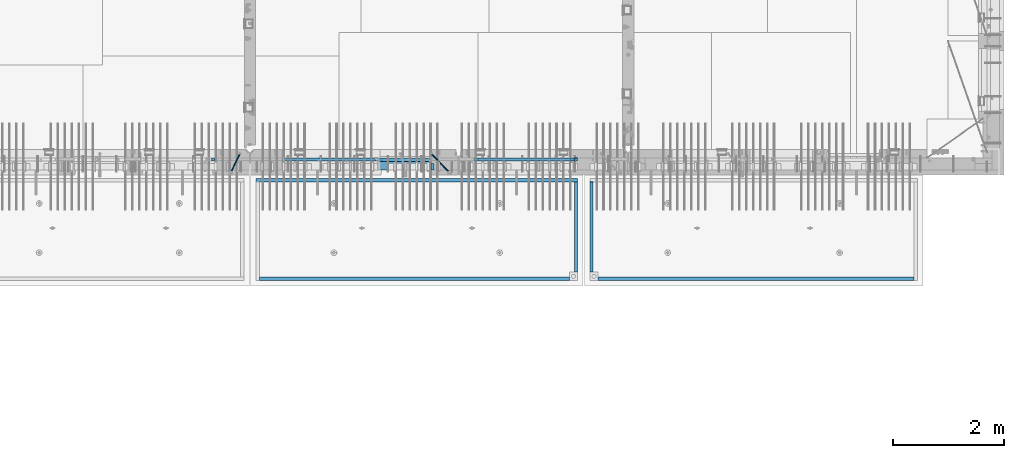
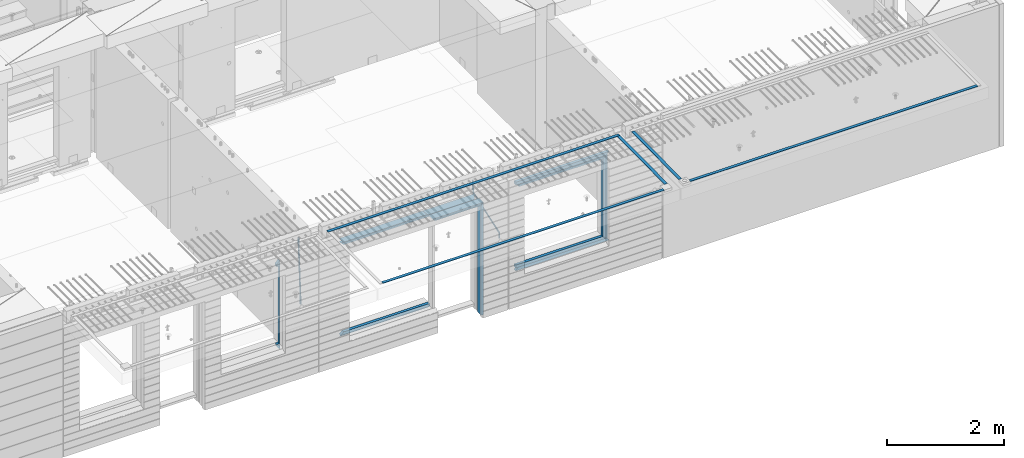
# One storey, part 96 of 352: 22 beams, 5 elements without a shape of their own.
"""IFC2X3 building model written with IfcOpenShell, lengths in millimetres."""

from ifc_helpers import new_model, si_unit, frame, origin_with_axes, place, context, subcontext, project, spatial, faceted_brep, material, type_object, element, aggregate, save


model = new_model("IFC2X3")

# Units and contexts
model_context = context("Model", 3, precision=1e-05, world=origin_with_axes())
body_context = subcontext(model_context, "Body", "Model", "MODEL_VIEW")
ifc_project = project(units=[si_unit("LENGTHUNIT", "METRE", prefix="MILLI"), si_unit("AREAUNIT", "SQUARE_METRE"), si_unit("VOLUMEUNIT", "CUBIC_METRE"), si_unit("MASSUNIT", "GRAM", prefix="KILO"), si_unit("TIMEUNIT", "SECOND"), si_unit("PLANEANGLEUNIT", "RADIAN"), si_unit("SOLIDANGLEUNIT", "STERADIAN"), si_unit("THERMODYNAMICTEMPERATUREUNIT", "DEGREE_CELSIUS"), si_unit("LUMINOUSINTENSITYUNIT", "LUMEN")], contexts=[model_context])

# Site, building, storey
site_placement = place(None, origin_with_axes())
site = spatial("IfcSite", under=ifc_project, at=site_placement, CompositionType="ELEMENT")
building_placement = place(site_placement, origin_with_axes())
building = spatial("IfcBuilding", under=site, at=building_placement, CompositionType="ELEMENT")
storey_placement = place(building_placement, origin_with_axes())
storey = spatial("IfcBuildingStorey", under=building, at=storey_placement, Name="6", CompositionType="ELEMENT", Elevation=0.0)

# Assembly, beams
assembly_1_placement = place(storey_placement, origin_with_axes())
assembly_1 = element("IfcElementAssembly", 1, at=assembly_1_placement, inside=storey, AssemblyPlace="NOTDEFINED", PredefinedType="REINFORCEMENT_UNIT")
ifc_material_1 = material(Name="CONCRETE/C35/45")
beam_type_1 = type_object("IfcBeamType", PredefinedType="NOTDEFINED")
beam_1_placement = place(assembly_1_placement, frame((24034.9998642727, 7815.0, 99140.0), z_axis=(0.0, 0.0, -1.0), x_axis=(1.0, 0.0, 0.0)))
beam_1 = element("IfcBeam", 2, at=beam_1_placement, type_object=beam_type_1, material=ifc_material_1, Name="SK", context=body_context, shape_type="Brep", body=[
    faceted_brep([(70.0000000000164, -35.0, 35.0), (70.0000000000164, 35.0, 35.0), (0.0, -35.0, -35.0), (1039.99961853026, -35.0, -35.0), (980.889062997325, -35.0, 35.0), (980.889062997325, 35.0, 35.0)], [[[0, 1, 2]], [[0, 2, 3, 4]], [[1, 0, 4, 5]], [[2, 1, 5, 3]], [[4, 3, 5]]]),
])
ifc_material_2 = material(Name="TIMBER")
beam_type_2 = type_object("IfcBeamType", Name="50X150", PredefinedType="NOTDEFINED")
beam_2_placement = place(assembly_1_placement, frame((24104.9998642727, 7705.0, 99080.0), z_axis=(0.0, 0.0, -1.0), x_axis=(1.0, 0.0, 0.0)))
beam_2 = element("IfcBeam", 3, at=beam_2_placement, type_object=beam_type_2, material=ifc_material_2, ObjectType="50X150", context=body_context, shape_type="Brep", body=[
    faceted_brep([(50.0000000000036, -75.0, 25.0), (50.0000000000036, 75.0, 25.0), (0.0, 75.0, -25.0), (0.0, -75.0, -25.0), (1009.99961853027, -75.0, -25.0), (959.999618530259, -75.0, 25.0), (959.999618530259, 75.0, 25.0), (1009.99961853027, 75.0, -25.0)], [[[0, 1, 2, 3]], [[0, 3, 4, 5]], [[1, 0, 5, 6]], [[2, 1, 6, 7]], [[3, 2, 7, 4]], [[6, 5, 4, 7]]]),
])

# Assembly, beam
assembly_2_placement = place(storey_placement, origin_with_axes())
assembly_2 = element("IfcElementAssembly", 4, at=assembly_2_placement, inside=storey, AssemblyPlace="NOTDEFINED", PredefinedType="REINFORCEMENT_UNIT")
ifc_material_3 = material()
beam_type_3 = type_object("IfcBeamType", Name="D20", PredefinedType="NOTDEFINED")
beam_3_placement = place(assembly_2_placement, frame((21625.0073331492, 7924.99999997881, 99407.5), z_axis=(-0.000415599999849952, -0.999999913638316, 0.0), x_axis=(-6.05680000062309e-05, -4.00000390151988e-09, -0.999999998165759)))
beam_3 = element("IfcBeam", 5, at=beam_3_placement, type_object=beam_type_3, material=ifc_material_3, Name="JM20", ObjectType="D20", context=body_context, shape_type="Brep", body=[
    faceted_brep([(-0.00060564729210455, -9.99999998165731, 0.0), (-0.000428079845733009, -7.07106779890455, -7.07106781186667), (119.575515501536, -7.07830994756296, -7.07106481604933), (119.575337932896, -10.0072421307195, -3.43332612828817e-06), (0.0, 0.0, -10.0), (119.575943836026, -0.00724214867295814, -9.99999700418266), (0.00042843479604926, 7.07106779888636, -7.07106781186303), (119.57637202373, 7.06382565022977, -7.07106481604933), (0.00060564729210455, 9.99999998166459, 3.63797880709171e-12), (119.576549238118, 9.99275783300072, 2.99581552098971e-06), (0.000428079845733009, 7.07106779890819, 7.07106781186667), (119.576371669405, 7.06382565024978, 7.07107080768037), (0.0, 0.0, 10.0), (119.57594333493, -0.00724214864203532, 10.0000029958155), (-0.000428434810601175, -7.07106779888272, 7.07106781186667), (119.575515147211, -7.07830994754295, 7.07107080768037), (123.006973508192, -7.07825951346604, -6.96785036235087), (122.582196132164, -10.0072047447829, 0.090452766209637), (123.182421564867, -0.00718632049392909, -9.89150999405319), (123.005765870272, 7.06387605862983, -6.9678969281922), (122.5804889344, 9.99279518261392, 0.090375952400791), (122.155712218591, 7.06384995171538, 7.14866812117907), (121.980264161975, -0.00722324126036256, 10.0723277528814), (122.156919856599, -7.07828562038412, 7.14871468701676), (235.904703171851, -7.06860422895625, -0.169508357435916), (235.479926262604, -9.99754169577864, 6.88878701985595), (236.080151695453, 0.002465748351824, -3.09317573838871), (235.903496467319, 7.07353134315781, -0.16957042179456), (235.478219724217, 10.0024582304504, 6.88869924890878), (235.053442814489, 7.07352076285679, 13.9469946275131), (234.877994290917, 0.00245078554871725, 16.8706620084649), (235.05464951905, -7.06861480925727, 13.9470566918726), (247.69730842374, 6.49890140729985, 1.5904257279044), (247.708271375333, -0.564091162203113, -1.35790592567901), (246.351191555892, -7.5775885142175, 1.3894260566567), (244.421027918448, -10.4331790195793, 8.22307186000126), (243.04844414418, -7.45809648886643, 15.1399744532118), (243.037481192529, -0.395103919359826, 18.0883061067871), (244.394561011999, 6.61839343264, 15.3409741244495), (246.324724649443, 9.47398393802723, 8.50732832109588), (256.620302657771, 7.90789673379186, 11.9850227549905), (258.892076862918, 4.79603600307382, 5.371853429986), (253.26121545503, 5.26966351612282, 18.3359992487194), (250.782522980895, -1.57322241172369, 20.7044670154446), (250.636209669712, -8.61229127897968, 17.7030097594688), (252.907983874131, -11.724152010418, 11.0898404357176), (256.267071077629, -9.08591879203959, 4.7388639407518), (258.745763551793, -2.24303286420036, 2.37039617402661), (1008.47908473376, -166.485147783689, 337.205828025195), (1005.11999753102, -169.123381001344, 343.556804518913), (1010.95777720789, -159.642261855857, 334.837360258474), (1011.10409051905, -152.60319298859, 337.838817514449), (1008.83231631388, -149.491332257865, 344.451986839456), (1005.47322911114, -152.129565475519, 350.802963333173), (1002.99453663701, -158.972451403351, 353.171431099895), (1002.84822332587, -166.011520270618, 350.169973843918), (1010.17087503639, -166.839152352099, 337.953575170377), (1008.40147312843, -169.810024819315, 345.007169854448), (1011.47638800017, -159.75078038171, 335.066578819891), (1011.55326023143, -152.697181073247, 338.037344110582), (1010.35646101969, -149.810257238067, 345.125637025791), (1008.58705911171, -152.781129705283, 352.179231709861), (1007.28154614793, -159.869501675676, 355.066228060347), (1007.20467391667, -166.923100984135, 352.095462769656), (1012.05411677422, -166.839038287919, 337.953575122971), (1012.05429688386, -169.809803575103, 345.007169762499), (1012.05368737834, -159.750745415844, 335.066578805359), (1012.05326023052, -152.697150789249, 338.037344097996), (1012.05308554815, -149.81015447692, 345.125636983083), (1012.05326565779, -152.780919764096, 352.179231622609), (1012.05369505366, -159.869212636178, 355.066227940223), (1012.05412220149, -166.92280726277, 352.095462647586), (1117.510115663, -166.832651029355, 337.953572468433), (1117.51029577265, -169.803416316539, 345.00716710796), (1117.50968626713, -159.744358157277, 335.06657615082), (1117.50925911931, -152.690763530685, 338.037341443456), (1117.50908443694, -149.803767218353, 345.125634328543), (1117.50926454658, -152.774532505533, 352.17922896807), (1117.50969394245, -159.862825377615, 355.066225285684), (1117.51012109026, -166.916420004207, 352.095459993046)], [[[0, 1, 2, 3]], [[1, 4, 5, 2]], [[4, 6, 7, 5]], [[6, 8, 9, 7]], [[8, 10, 11, 9]], [[10, 12, 13, 11]], [[12, 14, 15, 13]], [[14, 0, 3, 15]], [[14, 12, 10, 8, 6, 4, 1, 0]], [[3, 2, 16, 17]], [[2, 5, 18, 16]], [[5, 7, 19, 18]], [[7, 9, 20, 19]], [[9, 11, 21, 20]], [[11, 13, 22, 21]], [[13, 15, 23, 22]], [[15, 3, 17, 23]], [[17, 16, 24, 25]], [[16, 18, 26, 24]], [[18, 19, 27, 26]], [[19, 20, 28, 27]], [[20, 21, 29, 28]], [[21, 22, 30, 29]], [[22, 23, 31, 30]], [[23, 17, 25, 31]], [[26, 27, 32, 33]], [[24, 26, 33, 34]], [[25, 24, 34, 35]], [[31, 25, 35, 36]], [[30, 31, 36, 37]], [[29, 30, 37, 38]], [[28, 29, 38, 39]], [[27, 28, 39, 32]], [[39, 40, 41, 32]], [[38, 42, 40, 39]], [[37, 43, 42, 38]], [[36, 44, 43, 37]], [[35, 45, 44, 36]], [[34, 46, 45, 35]], [[33, 47, 46, 34]], [[32, 41, 47, 33]], [[45, 46, 48, 49]], [[46, 47, 50, 48]], [[47, 41, 51, 50]], [[41, 40, 52, 51]], [[40, 42, 53, 52]], [[42, 43, 54, 53]], [[43, 44, 55, 54]], [[44, 45, 49, 55]], [[49, 48, 56, 57]], [[48, 50, 58, 56]], [[50, 51, 59, 58]], [[51, 52, 60, 59]], [[52, 53, 61, 60]], [[53, 54, 62, 61]], [[54, 55, 63, 62]], [[55, 49, 57, 63]], [[57, 56, 64, 65]], [[56, 58, 66, 64]], [[58, 59, 67, 66]], [[59, 60, 68, 67]], [[60, 61, 69, 68]], [[61, 62, 70, 69]], [[62, 63, 71, 70]], [[63, 57, 65, 71]], [[65, 64, 72, 73]], [[64, 66, 74, 72]], [[66, 67, 75, 74]], [[67, 68, 76, 75]], [[68, 69, 77, 76]], [[69, 70, 78, 77]], [[70, 71, 79, 78]], [[71, 65, 73, 79]], [[74, 75, 76, 77, 78, 79, 73, 72]]]),
])

# Beam
beam_4_placement = place(assembly_1_placement, frame((25075.0293329014, 7924.99999993642, 99407.5), z_axis=(-0.000415599999849952, -0.999999913638316, 0.0), x_axis=(-0.000242263999929879, 0.0, -0.999999970654077)))
beam_4 = element("IfcBeam", 6, at=beam_4_placement, type_object=beam_type_3, material=ifc_material_3, Name="JM20", ObjectType="D20", context=body_context, shape_type="Brep", body=[
    faceted_brep([(-0.00060564729210455, -9.99999998165731, 0.0), (-0.000428079845733009, -7.07106779890455, -7.07106781186667), (119.575515501536, -7.07830994756296, -7.07106481604933), (119.575337932896, -10.0072421307195, -3.43332612828817e-06), (0.0, 0.0, -10.0), (119.575943836026, -0.00724214867295814, -9.99999700418266), (0.00042843479604926, 7.07106779888636, -7.07106781186303), (119.57637202373, 7.06382565022977, -7.07106481604933), (0.00060564729210455, 9.99999998166459, 3.63797880709171e-12), (119.576549238118, 9.99275783300072, 2.99581552098971e-06), (0.000428079845733009, 7.07106779890819, 7.07106781186667), (119.576371669405, 7.06382565024978, 7.07107080768037), (0.0, 0.0, 10.0), (119.57594333493, -0.00724214864203532, 10.0000029958155), (-0.000428434810601175, -7.07106779888272, 7.07106781186667), (119.575515147211, -7.07830994754295, 7.07107080768037), (123.008274907785, -7.07795567963694, -6.96780325792497), (122.584029738471, -10.0069316327917, 0.0905081323508057), (123.182440752484, -0.00686994861462153, -9.89150922917906), (123.004503280346, 7.06417944043824, -6.96794247666548), (122.578695849254, 9.99306765562687, 0.0903112464729929), (122.15445067735, 7.0640917031651, 7.14862263591931), (121.980284832651, -0.0069940278553986, 10.072328607177), (122.158222304832, -7.07804341691372, 7.14876185467801), (233.088395941915, -7.04853267872386, -0.33914435535371), (232.664150764584, -9.97750862893736, 6.71916703474017), (233.262561786629, 0.0225530520438042, -3.26285032724809), (233.08462431423, 7.09360244138225, -0.339283575355694), (232.658816882788, 10.0224906572403, 6.71897014756632), (232.234571710651, 7.09351470543697, 13.777281537301), (232.060405865923, 0.0224289746693103, 16.7009875091953), (232.238343338337, -7.04862041468004, 13.7774207573038), (248.070459246126, -5.60737147376494, 1.85103242021069), (247.013897852143, -8.59717146491312, 8.81690765643543), (244.865343898215, -5.8339984379636, 15.6233189364948), (242.883391151001, 1.06351832306973, 18.2831628436061), (242.22904064988, 8.05490704629119, 15.2383388907911), (243.285602043848, 11.0447070374539, 8.27246365456904), (245.434155997835, 8.28153401051895, 1.46605237452331), (247.416108745019, 1.38401724946743, -1.19379153259433), (260.512945877912, 5.37327174938764, 3.16696371259513), (261.933955342625, -1.38459511741894, 6.46705632785779), (256.86166640259, 11.762316953962, 5.27098446848322), (253.118986913221, 14.0399244660766, 11.5466117722399), (251.477318295016, 10.8719026949148, 18.3176682617204), (252.898327759729, 4.11403582813364, 21.6177608769931), (256.54960723508, -2.27500937642981, 19.5137401211105), (260.292286730517, -4.55261688891915, 13.2381128181169), (1011.6899267952, 318.016952836686, 337.688913324002), (1010.04825817693, 314.848931065488, 344.459969813425), (1010.26891733034, 324.774819703332, 334.388820708672), (1006.61763785462, 331.163864907652, 336.492841464405), (1002.87495836492, 333.441472419578, 342.76846876801), (1001.23328974665, 330.273450648383, 349.539525257433), (1002.6542992115, 323.515583781733, 352.839617872763), (1006.30557868723, 317.12653857741, 350.73559711703), (1012.11607330808, 318.198494379605, 337.877173297548), (1011.23010097447, 315.352404773395, 344.982075913254), (1011.34812648257, 325.234570724882, 334.865586047124), (1009.37611333313, 332.338995712049, 337.711461129013), (1007.35521241752, 335.350093536494, 344.747723517063), (1006.46924008391, 332.504003930284, 351.85262613277), (1007.23718690944, 325.467927585003, 354.864213383194), (1009.20920005886, 318.363502597836, 352.018338301305), (1012.61607329341, 318.198615511596, 337.877173247205), (1012.61676345688, 315.352740711776, 344.982075773638), (1012.61436835937, 325.234877489685, 334.865585919631), (1012.61264738202, 332.339779807688, 337.71146080314), (1012.61191848651, 335.351367047057, 344.747722987787), (1012.61260864999, 332.505492247237, 351.852625514221), (1012.61431358402, 325.469230269144, 354.864212841793), (1012.61603456138, 318.364327951142, 352.018337958285), (1117.42297412557, 318.224006449098, 337.87716269464), (1117.42366428903, 315.378131649279, 344.982065221072), (1117.42126919153, 325.260268427191, 334.865575367066), (1117.41954821418, 332.365170745194, 337.711450250575), (1117.41881931867, 335.376757984559, 344.747712435222), (1117.41950948215, 332.530883184736, 351.852614961655), (1117.42121441617, 325.494621206646, 354.864202289227), (1117.42293539354, 318.389718888644, 352.018327405719)], [[[0, 1, 2, 3]], [[1, 4, 5, 2]], [[4, 6, 7, 5]], [[6, 8, 9, 7]], [[8, 10, 11, 9]], [[10, 12, 13, 11]], [[12, 14, 15, 13]], [[14, 0, 3, 15]], [[14, 12, 10, 8, 6, 4, 1, 0]], [[3, 2, 16, 17]], [[2, 5, 18, 16]], [[5, 7, 19, 18]], [[7, 9, 20, 19]], [[9, 11, 21, 20]], [[11, 13, 22, 21]], [[13, 15, 23, 22]], [[15, 3, 17, 23]], [[17, 16, 24, 25]], [[16, 18, 26, 24]], [[18, 19, 27, 26]], [[19, 20, 28, 27]], [[20, 21, 29, 28]], [[21, 22, 30, 29]], [[22, 23, 31, 30]], [[23, 17, 25, 31]], [[25, 24, 32, 33]], [[31, 25, 33, 34]], [[30, 31, 34, 35]], [[29, 30, 35, 36]], [[28, 29, 36, 37]], [[27, 28, 37, 38]], [[26, 27, 38, 39]], [[24, 26, 39, 32]], [[39, 40, 41, 32]], [[38, 42, 40, 39]], [[37, 43, 42, 38]], [[36, 44, 43, 37]], [[35, 45, 44, 36]], [[34, 46, 45, 35]], [[33, 47, 46, 34]], [[32, 41, 47, 33]], [[47, 41, 48, 49]], [[41, 40, 50, 48]], [[40, 42, 51, 50]], [[42, 43, 52, 51]], [[43, 44, 53, 52]], [[44, 45, 54, 53]], [[45, 46, 55, 54]], [[46, 47, 49, 55]], [[49, 48, 56, 57]], [[48, 50, 58, 56]], [[50, 51, 59, 58]], [[51, 52, 60, 59]], [[52, 53, 61, 60]], [[53, 54, 62, 61]], [[54, 55, 63, 62]], [[55, 49, 57, 63]], [[57, 56, 64, 65]], [[56, 58, 66, 64]], [[58, 59, 67, 66]], [[59, 60, 68, 67]], [[60, 61, 69, 68]], [[61, 62, 70, 69]], [[62, 63, 71, 70]], [[63, 57, 65, 71]], [[65, 64, 72, 73]], [[64, 66, 74, 72]], [[66, 67, 75, 74]], [[67, 68, 76, 75]], [[68, 69, 77, 76]], [[69, 70, 78, 77]], [[70, 71, 79, 78]], [[71, 65, 73, 79]], [[74, 75, 76, 77, 78, 79, 73, 72]]]),
])

# Assembly, beams
assembly_3_placement = place(storey_placement, origin_with_axes())
assembly_3 = element("IfcElementAssembly", 7, at=assembly_3_placement, inside=storey, AssemblyPlace="NOTDEFINED", PredefinedType="REINFORCEMENT_UNIT")
ifc_material_4 = material(Name="CONCRETE/Concrete_Undefined")
beam_type_4 = type_object("IfcBeamType", PredefinedType="NOTDEFINED")
beam_5_placement = place(assembly_3_placement, frame((27949.9413896323, 7420.0548526853, 99725.6636564041), z_axis=(3.20999999465459e-07, -0.00901957599816896, 0.999959322797038), x_axis=(3.55380000057318e-05, -0.999959322165559, -0.00901957600149657)))
beam_5 = element("IfcBeam", 8, at=beam_5_placement, type_object=beam_type_4, material=ifc_material_4, context=body_context, shape_type="Brep", body=[
    faceted_brep([(2.5465851649642e-11, 29.9999999999982, -4.99999999998545), (-2.91038304567337e-11, 29.9999999999982, 5.0), (1625.35189228369, 30.0000000000073, 5.0), (1625.35189228371, 30.0000000000073, -5.0), (-2.5465851649642e-11, -30.0000000000018, 5.0), (1625.35189228368, -29.9999999999927, 5.00000000001455), (2.72848410531878e-11, -30.0000000000018, -4.99999999998545), (1625.35189228371, -29.9999999999927, -4.99999999998545)], [[[0, 1, 2, 3]], [[1, 4, 5, 2]], [[4, 6, 7, 5]], [[6, 0, 3, 7]], [[5, 7, 3, 2]], [[6, 4, 1, 0]]]),
])
beam_6_placement = place(assembly_3_placement, frame((33750.1798578673, 5674.89208457699, 99711.2777998596), z_axis=(-0.00010875600001081, -1.00000033862182e-09, 0.999999994086066), x_axis=(-0.999999994070015, -5.66600000038745e-06, -0.000108756000006807)))
beam_6 = element("IfcBeam", 9, at=beam_6_placement, type_object=beam_type_4, material=ifc_material_4, context=body_context, shape_type="Brep", body=[
    faceted_brep([(2.5465851649642e-11, 29.9999999999982, -4.99999999998545), (-2.91038304567337e-11, 29.9999999999982, 5.0), (5682.56261276337, 30.0, 5.0), (5682.56261276337, 30.0, -5.0), (-2.5465851649642e-11, -30.0000000000018, 5.0), (5682.56261276337, -30.0, 5.0), (2.72848410531878e-11, -30.0000000000018, -4.99999999998545), (5682.56261276337, -30.0, -5.0)], [[[0, 1, 2, 3]], [[1, 4, 5, 2]], [[4, 6, 7, 5]], [[6, 0, 3, 7]], [[5, 7, 3, 2]], [[6, 4, 1, 0]]]),
])
aggregate(assembly_3, [beam_5, beam_6])

assembly_4_placement = place(storey_placement, origin_with_axes())
assembly_4 = element("IfcElementAssembly", 10, at=assembly_4_placement, inside=storey, AssemblyPlace="NOTDEFINED", PredefinedType="REINFORCEMENT_UNIT")
beam_7_placement = place(assembly_4_placement, frame((27670.0013901304, 7419.94686420498, 99725.2791047129), z_axis=(-7.99999906695021e-09, -0.0106298469955396, 0.99994350158039), x_axis=(-7.67999998664137e-07, -0.999943501580095, -0.0106298469955353)))
beam_7 = element("IfcBeam", 11, at=beam_7_placement, type_object=beam_type_4, material=ifc_material_4, context=body_context, shape_type="Brep", body=[
    faceted_brep([(2.5465851649642e-11, 29.9999999999982, -4.99999999998545), (-2.91038304567337e-11, 29.9999999999982, 5.0), (1625.17584384035, 29.9999999999964, 5.0), (1625.17584384035, 30.0000000000036, -4.99999999998545), (-2.5465851649642e-11, -30.0000000000018, 5.0), (1625.17584384035, -30.0, 5.0), (2.72848410531878e-11, -30.0000000000018, -4.99999999998545), (1625.17584384035, -29.9999999999964, -4.99999999998545)], [[[0, 1, 2, 3]], [[1, 4, 5, 2]], [[4, 6, 7, 5]], [[6, 0, 3, 7]], [[5, 7, 3, 2]], [[6, 4, 1, 0]]]),
])
beam_8_placement = place(assembly_4_placement, frame((27700.0033616247, 7449.93184428144, 99725.2788442816), z_axis=(6.6541999986247e-05, -1.00000033832184e-09, 0.999999997786081), x_axis=(-0.999999997707994, 1.24969999963762e-05, 6.65419999798477e-05)))
beam_8 = element("IfcBeam", 12, at=beam_8_placement, type_object=beam_type_4, material=ifc_material_4, context=body_context, shape_type="Brep", body=[
    faceted_brep([(2.5465851649642e-11, 29.9999999999982, -4.99999999998545), (-2.91038304567337e-11, 29.9999999999982, 5.0), (5780.0600107005, 30.0, 5.00000000001455), (5780.0600107005, 30.0000000000009, -5.0), (-2.5465851649642e-11, -30.0000000000018, 5.0), (5780.0600107005, -30.0000000000009, 5.00000000001455), (2.72848410531878e-11, -30.0000000000018, -4.99999999998545), (5780.0600107005, -30.0, -4.99999999998545)], [[[0, 1, 2, 3]], [[1, 4, 5, 2]], [[4, 6, 7, 5]], [[6, 0, 3, 7]], [[5, 7, 3, 2]], [[6, 4, 1, 0]]]),
])
beam_9_placement = place(assembly_4_placement, frame((21979.9397016438, 5674.8679591, 99709.8457712343), z_axis=(0.000327872000083623, 1.99999976807677e-09, 0.999999946249974), x_axis=(0.999999946233322, 5.77100000136594e-06, -0.000327872000077393)))
beam_9 = element("IfcBeam", 13, at=beam_9_placement, type_object=beam_type_4, material=ifc_material_4, context=body_context, shape_type="Brep", body=[
    faceted_brep([(2.5465851649642e-11, 29.9999999999982, -4.99999999998545), (-2.91038304567337e-11, 29.9999999999982, 5.0), (5570.052902922, 30.0000000000009, 5.00000000001455), (5570.05290292199, 30.0000000000009, -4.99999999998545), (-2.5465851649642e-11, -30.0000000000018, 5.0), (5570.052902922, -30.0, 5.00000000001455), (2.72848410531878e-11, -30.0000000000018, -4.99999999998545), (5570.05290292199, -30.0, -4.99999999998545)], [[[0, 1, 2, 3]], [[1, 4, 5, 2]], [[4, 6, 7, 5]], [[6, 0, 3, 7]], [[5, 7, 3, 2]], [[6, 4, 1, 0]]]),
])
aggregate(assembly_4, [beam_7, beam_8, beam_9])

# Beam
beam_type_5 = type_object("IfcBeamType", PredefinedType="NOTDEFINED")
beam_10_placement = place(assembly_2_placement, frame((21144.9998642727, 7820.0, 99175.0), z_axis=(-1.0, 3.00000001838171e-08, 0.0), x_axis=(0.0, 0.0, -1.0)))
beam_10 = element("IfcBeam", 14, at=beam_10_placement, type_object=beam_type_5, material=ifc_material_1, Name="SK", context=body_context, shape_type="Brep", body=[
    faceted_brep([(1740.94594594595, -30.0, 30.0), (1739.32432432432, 30.0, 30.0), (1739.32432432432, 30.0, -24.3243243243269), (1740.94594594595, -30.0, -25.9459459459504), (115.67567567568, 30.0, -24.3243243243269), (114.054054054053, -30.0, -25.9459459459504), (115.67567567568, 30.0, 30.0), (114.054054054053, -30.0, 30.0), (72.2635272671032, 30.0, 30.0), (72.2635272671032, -30.0, 30.0), (0.0, 30.0, -30.0), (0.0, -30.0, -30.0), (1855.0, -30.0, -30.0), (1782.73647273288, -30.0, 30.0), (1782.73647273287, 30.0, 30.0), (1855.0, 30.0, -30.0)], [[[0, 1, 2, 3]], [[3, 2, 4, 5]], [[5, 4, 6, 7]], [[7, 6, 8, 9]], [[10, 11, 9, 8]], [[0, 3, 5, 7, 9, 11, 12, 13]], [[1, 0, 13, 14]], [[10, 8, 6, 4, 2, 1, 14, 15]], [[15, 12, 11, 10]], [[15, 14, 13, 12]]]),
])

beam_11_placement = place(assembly_1_placement, frame((22384.9998642751, 7820.0, 99145.0), z_axis=(0.0, 0.0, -1.0), x_axis=(1.0, 0.0, 0.0)))
beam_11 = element("IfcBeam", 15, at=beam_11_placement, type_object=beam_type_5, material=ifc_material_1, Name="SK", context=body_context, shape_type="Brep", body=[
    faceted_brep([(1820.00000000026, -30.0, 30.0), (1820.00000000026, -30.0, -30.0), (1820.00000000026, 30.0, 30.0), (49.817662327685, -30.0, 30.0), (0.0, -30.0, -30.0), (49.817662327685, 30.0, 30.0)], [[[0, 1, 2]], [[1, 0, 3, 4]], [[2, 1, 4, 5]], [[0, 2, 5, 3]], [[4, 3, 5]]]),
])

beam_12_placement = place(assembly_1_placement, frame((22384.9998642751, 7820.0, 99085.0), z_axis=(0.0, 0.0, -1.0), x_axis=(1.0, 0.0, 0.0)))
beam_12 = element("IfcBeam", 16, at=beam_12_placement, type_object=beam_type_5, material=ifc_material_1, Name="SK", context=body_context, shape_type="Brep", body=[
    faceted_brep([(1820.00000000026, -30.0, -30.0), (1820.00000000026, 30.0, -30.0), (1820.00000000026, 30.0, 25.6756756756804), (1820.00000000026, -30.0, 24.0540540540678), (59.8219112435072, 30.0, 25.6756756756804), (58.0795254791192, -30.0, 24.0540540540533), (0.0, -30.0, -30.0), (0.0, 30.0, -30.0)], [[[0, 1, 2, 3]], [[3, 2, 4, 5]], [[0, 3, 5, 6]], [[6, 7, 1, 0]], [[2, 1, 7, 4]], [[4, 7, 6, 5]]]),
])

beam_13_placement = place(assembly_1_placement, frame((24144.9998642753, 7820.0, 97150.0), z_axis=(0.0, 0.0, 1.0), x_axis=(-1.0, 3.00000001838171e-08, 0.0)))
beam_13 = element("IfcBeam", 17, at=beam_13_placement, type_object=beam_type_5, material=ifc_material_1, Name="SK", context=body_context, shape_type="Brep", body=[
    faceted_brep([(0.0, -30.0, 30.0), (-5.28234522789717e-09, 30.0, 30.0), (0.0, -30.0, -30.0), (1710.18233767259, -30.0, 30.0), (1710.18233767259, 30.0, 30.0), (1760.00000000026, -30.0, -30.0)], [[[0, 1, 2]], [[1, 0, 3, 4]], [[2, 1, 4, 5]], [[0, 2, 5, 3]], [[4, 3, 5]]]),
])

beam_14_placement = place(assembly_1_placement, frame((24144.9998642753, 7820.0, 97210.0), z_axis=(0.0, 0.0, 1.0), x_axis=(-1.0, 3.00000001838171e-08, 0.0)))
beam_14 = element("IfcBeam", 18, at=beam_14_placement, type_object=beam_type_5, material=ifc_material_1, Name="SK", context=body_context, shape_type="Brep", body=[
    faceted_brep([(0.0, 30.0, -30.0), (0.0, -30.0, -30.0), (0.0, -30.0, 24.0540540540678), (0.0, 30.0, 25.6756756756804), (1700.17808875675, 30.0, 25.6756756756804), (1760.00000000026, 30.0, -30.0), (1760.00000000026, -30.0, -30.0), (1701.92047452114, -30.0, 24.0540540540533)], [[[0, 1, 2, 3]], [[0, 3, 4, 5]], [[1, 0, 5, 6]], [[2, 1, 6, 7]], [[3, 2, 7, 4]], [[6, 5, 4, 7]]]),
])

# Assembly, beams
assembly_5_placement = place(storey_placement, origin_with_axes())
assembly_5 = element("IfcElementAssembly", 19, at=assembly_5_placement, inside=storey, AssemblyPlace="NOTDEFINED", PredefinedType="REINFORCEMENT_UNIT")
beam_15_placement = place(assembly_5_placement, frame((25845.0006272121, 7820.0, 99145.0), z_axis=(0.0, 0.0, -1.0), x_axis=(1.0, 0.0, 0.0)))
beam_15 = element("IfcBeam", 20, at=beam_15_placement, type_object=beam_type_5, material=ifc_material_1, Name="SK", context=body_context, shape_type="Brep", body=[
    faceted_brep([(0.0, -30.0, -30.0), (0.0, -30.0, 30.0), (-5.28234522789717e-09, 30.0, 30.0), (0.0, 30.0, -30.0), (1849.99885559082, -30.0, -30.0), (1789.99885559081, -30.0, 30.0), (1789.99885559081, 30.0, 30.0), (1849.99885559082, 30.0, -30.0)], [[[0, 1, 2, 3]], [[1, 0, 4, 5]], [[2, 1, 5, 6]], [[3, 2, 6, 7]], [[0, 3, 7, 4]], [[6, 5, 4, 7]]]),
])
beam_16_placement = place(assembly_5_placement, frame((25905.0006272121, 7820.0, 99085.0), z_axis=(0.0, 0.0, -1.0), x_axis=(1.0, 0.0, 0.0)))
beam_16 = element("IfcBeam", 21, at=beam_16_placement, type_object=beam_type_5, material=ifc_material_1, Name="SK", context=body_context, shape_type="Brep", body=[
    faceted_brep([(1665.94480153677, -30.0, 24.0540540540533), (1664.32317991515, 30.0, 25.6756756756804), (0.0, 30.0, 25.6756756756804), (0.0, -30.0, 24.0540540540678), (0.0, 30.0, -30.0), (0.0, -30.0, -30.0), (1729.99885559082, -30.0, -30.0), (1665.94480153677, -30.0, 24.9034748914419), (1664.32317991515, 30.0, 26.293436281092), (1729.99885559082, 30.0, -30.0)], [[[0, 1, 2, 3]], [[4, 5, 3, 2]], [[0, 3, 5, 6, 7]], [[1, 0, 7, 8]], [[4, 2, 1, 8, 9]], [[5, 4, 9, 6]], [[8, 7, 6, 9]]]),
])
beam_17_placement = place(assembly_5_placement, frame((27664.9994828029, 7820.0, 99175.0), z_axis=(-1.0, 3.00000001838171e-08, 0.0), x_axis=(0.0, 0.0, -1.0)))
beam_17 = element("IfcBeam", 22, at=beam_17_placement, type_object=beam_type_5, material=ifc_material_1, Name="SK", context=body_context, shape_type="Brep", body=[
    faceted_brep([(60.0000000000073, 30.0, 30.0), (0.0, -30.0, -30.0), (60.0000000000073, -30.0, 30.0), (1855.0, -30.0, -30.0), (1795.00000000001, -30.0, 30.0), (1795.00000000001, 30.0, 30.0)], [[[0, 1, 2]], [[3, 4, 2, 1]], [[4, 5, 0, 2]], [[5, 3, 1, 0]], [[4, 3, 5]]]),
])
beam_18_placement = place(assembly_5_placement, frame((27694.9994828029, 7820.0, 97350.0), z_axis=(0.0, 0.0, 1.0), x_axis=(-1.0, 3.00000001838171e-08, 0.0)))
beam_18 = element("IfcBeam", 23, at=beam_18_placement, type_object=beam_type_5, material=ifc_material_1, Name="SK", context=body_context, shape_type="Brep", body=[
    faceted_brep([(1849.99885559082, 30.0, -30.0), (1800.18119326315, 30.0, 30.0), (1800.18119326315, -30.0, 30.0), (1849.99885559082, -30.0, -30.0), (0.0, -30.0, -30.0), (0.0, 30.0, -30.0), (60.0000000000073, 30.0, 30.0), (60.0000000000073, -30.0, 30.0)], [[[0, 1, 2, 3]], [[4, 5, 0, 3]], [[1, 0, 5, 6]], [[2, 1, 6, 7]], [[3, 2, 7, 4]], [[6, 5, 4, 7]]]),
])
beam_19_placement = place(assembly_5_placement, frame((27634.9994828029, 7820.0, 97410.0), z_axis=(0.0, 0.0, 1.0), x_axis=(-1.0, 3.00000001838171e-08, 0.0)))
beam_19 = element("IfcBeam", 24, at=beam_19_placement, type_object=beam_type_5, material=ifc_material_1, Name="SK", context=body_context, shape_type="Brep", body=[
    faceted_brep([(1785.94885559082, 30.0, 30.0), (1784.32432432432, 30.0, 30.0), (1785.94885559082, -30.0, 30.0), (1785.94885559082, -30.0, 24.0540519302303), (1784.32432432433, 30.0, 25.6756756756804), (65.6756756756768, 30.0, 25.6756756756804), (64.0540540540533, -30.0, 24.0540540540533), (1785.94885559082, -30.0, -30.0), (1785.94885559082, 30.0, -30.0), (0.0, -30.0, -30.0), (0.0, 30.0, -30.0), (65.6756756756768, 30.0, 26.293436281092), (64.0540540540533, -30.0, 24.9034748914419)], [[[0, 1, 2]], [[3, 4, 5, 6]], [[1, 4, 3, 2]], [[7, 8, 0, 2, 3]], [[8, 7, 9, 10]], [[5, 4, 1, 0, 8, 10, 11]], [[6, 5, 11, 12]], [[7, 3, 6, 12, 9]], [[9, 12, 11, 10]]]),
])

# Beam
beam_type_6 = type_object("IfcBeamType", PredefinedType="NOTDEFINED")
beam_20_placement = place(assembly_2_placement, frame((21139.9998642727, 7820.0, 99115.0), z_axis=(-1.0, 3.00000001838171e-08, 0.0), x_axis=(0.0, 0.0, -1.0)))
beam_20 = element("IfcBeam", 25, at=beam_20_placement, type_object=beam_type_6, material=ifc_material_1, Name="SK", context=body_context, shape_type="Brep", body=[
    faceted_brep([(1680.94594594595, -30.0, -30.9459459459504), (1679.32432432432, 30.0, -29.3243243243269), (55.6756756756804, 30.0, -29.3243243243269), (54.0540540540533, -30.0, -30.9459459459504), (55.6756756756804, 30.0, 24.8219112435145), (54.0540540540533, -30.0, 23.0795254791374), (0.0, 30.0, -35.0), (0.0, -30.0, -35.0), (1735.0, -30.0, -35.0), (1680.94594594595, -30.0, 23.0795254791337), (1679.32432432432, 30.0, 24.8219112435145), (1735.0, 30.0, -35.0)], [[[0, 1, 2, 3]], [[3, 2, 4, 5]], [[4, 6, 7, 5]], [[0, 3, 5, 7, 8, 9]], [[1, 0, 9, 10]], [[6, 4, 2, 1, 10, 11]], [[11, 8, 7, 6]], [[10, 9, 8, 11]]]),
])

aggregate(assembly_2, [beam_3, beam_10, beam_20])

beam_21_placement = place(assembly_5_placement, frame((27599.9994828029, 7820.0, 99115.0), z_axis=(-1.0, 3.00000001838171e-08, 0.0), x_axis=(0.0, 0.0, -1.0)))
beam_21 = element("IfcBeam", 26, at=beam_21_placement, type_object=beam_type_6, material=ifc_material_1, Name="SK", context=body_context, shape_type="Brep", body=[
    faceted_brep([(0.0, -30.0, -35.0), (54.9034748914273, -30.0, 29.0540540540533), (56.2934362811066, 30.0, 30.6756756756768), (0.0, 30.0, -35.0), (1735.0, -30.0, -35.0), (1680.09652510857, -30.0, 29.0540540540533), (1678.70656371891, 30.0, 30.6756756756768), (1735.0, 30.0, -35.0)], [[[0, 1, 2, 3]], [[1, 0, 4, 5]], [[2, 1, 5, 6]], [[3, 2, 6, 7]], [[7, 4, 0, 3]], [[4, 7, 6, 5]]]),
])

aggregate(assembly_5, [beam_15, beam_16, beam_17, beam_21, beam_18, beam_19])

beam_type_7 = type_object("IfcBeamType", Name="50X120", PredefinedType="NOTDEFINED")
beam_22_placement = place(assembly_1_placement, frame((25089.9994828029, 7690.0, 99105.0), z_axis=(-1.0, 3.00000001838171e-08, 0.0), x_axis=(0.0, 0.0, -1.0)))
beam_22 = element("IfcBeam", 27, at=beam_22_placement, type_object=beam_type_7, material=ifc_material_2, ObjectType="50X120", context=body_context, shape_type="Brep", body=[
    faceted_brep([(2345.0, -60.0, 25.0), (2345.0, -60.0, -25.0), (2345.0, 60.0, -25.0), (2345.0, 60.0, 25.0), (0.0, -60.0, -25.0), (0.0, 60.0, -25.0), (50.0000000000036, 60.0, 25.0), (50.0000000000036, -60.0, 25.0)], [[[0, 1, 2, 3]], [[4, 5, 2, 1]], [[3, 2, 5, 6]], [[0, 3, 6, 7]], [[1, 0, 7, 4]], [[5, 4, 7, 6]]]),
])

aggregate(assembly_1, [beam_4, beam_11, beam_12, beam_13, beam_14, beam_1, beam_2, beam_22])

save(model, "model.ifc")
